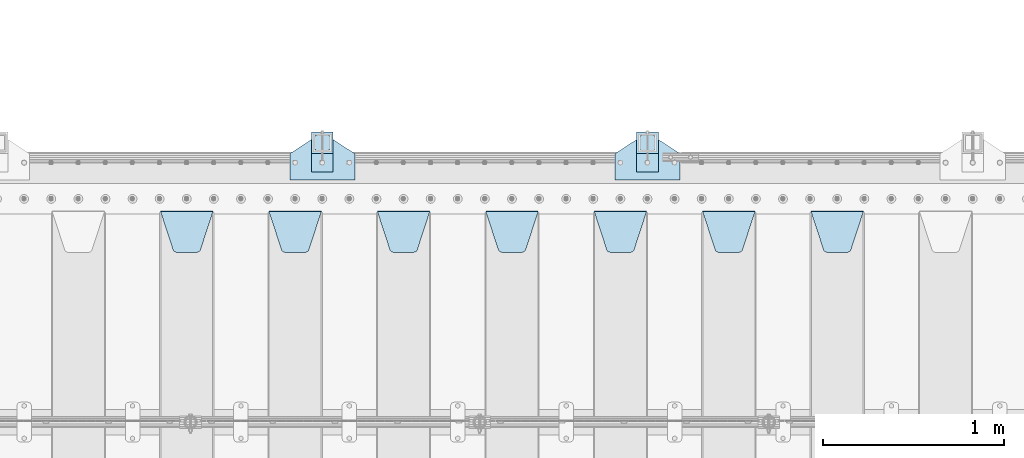
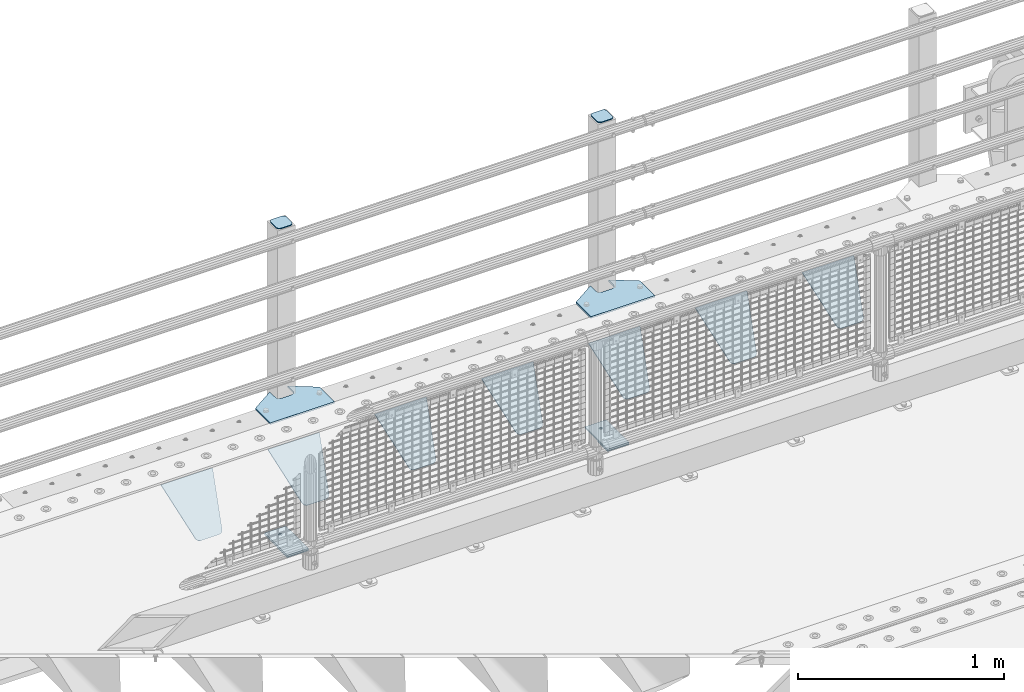
# One storey, part 183 of 208: 15 plates.
"""IFC2X3 building model written with IfcOpenShell, lengths in millimetres."""

from ifc_helpers import new_model, si_unit, frame, origin_with_axes, place, context, subcontext, project, spatial, faceted_brep, material, type_object, element, save


model = new_model("IFC2X3")

# Units and contexts
model_context = context("Model", 3, precision=1e-05, world=origin_with_axes())
body_context = subcontext(model_context, "Body", "Model", "MODEL_VIEW")
ifc_project = project(units=[si_unit("LENGTHUNIT", "METRE", prefix="MILLI"), si_unit("AREAUNIT", "SQUARE_METRE"), si_unit("VOLUMEUNIT", "CUBIC_METRE"), si_unit("MASSUNIT", "GRAM", prefix="KILO"), si_unit("TIMEUNIT", "SECOND"), si_unit("PLANEANGLEUNIT", "RADIAN"), si_unit("SOLIDANGLEUNIT", "STERADIAN"), si_unit("THERMODYNAMICTEMPERATUREUNIT", "DEGREE_CELSIUS"), si_unit("LUMINOUSINTENSITYUNIT", "LUMEN")], contexts=[model_context])

# Site, building, storey
site_placement = place(None, origin_with_axes())
site = spatial("IfcSite", under=ifc_project, at=site_placement, CompositionType="ELEMENT")
building_placement = place(site_placement, origin_with_axes())
building = spatial("IfcBuilding", under=site, at=building_placement, Name="Standard", CompositionType="ELEMENT")
storey_placement = place(building_placement, origin_with_axes())
storey = spatial("IfcBuildingStorey", under=building, at=storey_placement, Name="Undefined", CompositionType="ELEMENT", Elevation=0.0)

# Plates
ifc_material_1 = material(Name="STEEL/S355N")
plate_type_1 = type_object("IfcPlateType", PredefinedType="NOTDEFINED")
plate_1_placement = place(storey_placement, frame((-31995.0, 5831.76776695596, -1.76776695296758), z_axis=(0.0, -0.707106781186548, -0.707106781186547), x_axis=(1.0, 0.0, 0.0)))
element("IfcPlate", 1, at=plate_1_placement, inside=storey, type_object=plate_type_1, material=ifc_material_1, context=body_context, shape_type="Brep", body=[
    faceted_brep([(0.0, -2.5, 0.0), (69.345504679477, -2.5, 300.17173142483), (69.345504679477, 2.5, 300.17173142483), (0.0, 2.5, 0.0), (70.9274061199576, -2.5, 304.897442415399), (70.9274061199576, 2.5, 304.8974424154), (73.3818627772307, -2.5, 309.234538108527), (73.3818627772307, 2.5, 309.234538108527), (76.6187032999551, -2.5, 313.023683126103), (76.6187032999551, 2.5, 313.023683126103), (80.5190132704993, -2.5, 316.125672595371), (80.5190132704993, 2.5, 316.125672595371), (84.9395038596849, -2.5, 318.426546230476), (84.9395038596849, 2.50000000000091, 318.426546230476), (89.7177759439219, -2.5, 319.841774983275), (89.7177759439219, 2.50000000000091, 319.841774983275), (94.678286292652, -2.49999999999909, 320.319366455078), (94.678286292652, 2.5, 320.319366455078), (195.321713707348, -2.49999999999909, 320.319366455078), (195.321713707348, 2.5, 320.319366455078), (200.282224056078, -2.5, 319.841774983275), (200.282224056078, 2.5, 319.841774983274), (205.060496140315, -2.5, 318.426546230475), (205.060496140315, 2.5, 318.426546230475), (209.480986729501, -2.5, 316.125672595371), (209.480986729501, 2.50000000000091, 316.125672595371), (213.381296700045, -2.5, 313.023683126102), (213.381296700045, 2.5, 313.023683126102), (216.618137222769, -2.5, 309.234538108526), (216.618137222769, 2.5, 309.234538108527), (219.072593880042, -2.5, 304.897442415399), (219.072593880042, 2.5, 304.897442415399), (220.654495320523, -2.5, 300.17173142483), (220.654495320523, 2.5, 300.17173142483), (290.0, -2.5, 0.0), (290.0, 2.5, 0.0)], [[[0, 1, 2, 3]], [[1, 4, 5, 2]], [[4, 6, 7, 5]], [[6, 8, 9, 7]], [[8, 10, 11, 9]], [[10, 12, 13, 11]], [[12, 14, 15, 13]], [[14, 16, 17, 15]], [[16, 18, 19, 17]], [[18, 20, 21, 19]], [[20, 22, 23, 21]], [[22, 24, 25, 23]], [[24, 26, 27, 25]], [[26, 28, 29, 27]], [[28, 30, 31, 29]], [[30, 32, 33, 31]], [[32, 34, 35, 33]], [[34, 0, 3, 35]], [[5, 7, 9, 11, 13, 15, 17, 19, 21, 23, 25, 27, 29, 31, 33, 35, 3, 2]], [[34, 32, 30, 28, 26, 24, 22, 20, 18, 16, 14, 12, 10, 8, 6, 4, 1, 0]]]),
])
plate_2_placement = place(storey_placement, frame((-32595.0, 5831.76776695596, -1.76776695296758), z_axis=(0.0, -0.707106781186548, -0.707106781186547), x_axis=(1.0, 0.0, 0.0)))
element("IfcPlate", 2, at=plate_2_placement, inside=storey, type_object=plate_type_1, material=ifc_material_1, context=body_context, shape_type="Brep", body=[
    faceted_brep([(0.0, -2.5, 0.0), (69.345504679477, -2.5, 300.17173142483), (69.345504679477, 2.5, 300.17173142483), (0.0, 2.5, 0.0), (70.9274061199576, -2.5, 304.897442415399), (70.9274061199576, 2.5, 304.8974424154), (73.3818627772307, -2.5, 309.234538108527), (73.3818627772307, 2.5, 309.234538108527), (76.6187032999551, -2.5, 313.023683126103), (76.6187032999551, 2.5, 313.023683126103), (80.5190132704993, -2.5, 316.125672595371), (80.5190132704993, 2.5, 316.125672595371), (84.9395038596849, -2.5, 318.426546230476), (84.9395038596849, 2.50000000000091, 318.426546230476), (89.7177759439219, -2.5, 319.841774983275), (89.7177759439219, 2.50000000000091, 319.841774983275), (94.678286292652, -2.49999999999909, 320.319366455078), (94.678286292652, 2.5, 320.319366455078), (195.321713707348, -2.49999999999909, 320.319366455078), (195.321713707348, 2.5, 320.319366455078), (200.282224056078, -2.5, 319.841774983275), (200.282224056078, 2.5, 319.841774983274), (205.060496140315, -2.5, 318.426546230475), (205.060496140315, 2.5, 318.426546230475), (209.480986729501, -2.5, 316.125672595371), (209.480986729501, 2.50000000000091, 316.125672595371), (213.381296700045, -2.5, 313.023683126102), (213.381296700045, 2.5, 313.023683126102), (216.618137222769, -2.5, 309.234538108526), (216.618137222769, 2.5, 309.234538108527), (219.072593880042, -2.5, 304.897442415399), (219.072593880042, 2.5, 304.897442415399), (220.654495320523, -2.5, 300.17173142483), (220.654495320523, 2.5, 300.17173142483), (290.0, -2.5, 0.0), (290.0, 2.5, 0.0)], [[[0, 1, 2, 3]], [[1, 4, 5, 2]], [[4, 6, 7, 5]], [[6, 8, 9, 7]], [[8, 10, 11, 9]], [[10, 12, 13, 11]], [[12, 14, 15, 13]], [[14, 16, 17, 15]], [[16, 18, 19, 17]], [[18, 20, 21, 19]], [[20, 22, 23, 21]], [[22, 24, 25, 23]], [[24, 26, 27, 25]], [[26, 28, 29, 27]], [[28, 30, 31, 29]], [[30, 32, 33, 31]], [[32, 34, 35, 33]], [[34, 0, 3, 35]], [[5, 7, 9, 11, 13, 15, 17, 19, 21, 23, 25, 27, 29, 31, 33, 35, 3, 2]], [[34, 32, 30, 28, 26, 24, 22, 20, 18, 16, 14, 12, 10, 8, 6, 4, 1, 0]]]),
])
plate_3_placement = place(storey_placement, frame((-33195.0, 5831.76776695596, -1.76776695296758), z_axis=(0.0, -0.707106781186548, -0.707106781186547), x_axis=(1.0, 0.0, 0.0)))
element("IfcPlate", 3, at=plate_3_placement, inside=storey, type_object=plate_type_1, material=ifc_material_1, context=body_context, shape_type="Brep", body=[
    faceted_brep([(0.0, -2.5, 0.0), (69.345504679477, -2.5, 300.17173142483), (69.345504679477, 2.5, 300.17173142483), (0.0, 2.5, 0.0), (70.9274061199576, -2.5, 304.897442415399), (70.9274061199576, 2.5, 304.8974424154), (73.3818627772307, -2.5, 309.234538108527), (73.3818627772307, 2.5, 309.234538108527), (76.6187032999551, -2.5, 313.023683126103), (76.6187032999551, 2.5, 313.023683126103), (80.5190132704993, -2.5, 316.125672595371), (80.5190132704993, 2.5, 316.125672595371), (84.9395038596849, -2.5, 318.426546230476), (84.9395038596849, 2.50000000000091, 318.426546230476), (89.7177759439219, -2.5, 319.841774983275), (89.7177759439219, 2.50000000000091, 319.841774983275), (94.678286292652, -2.49999999999909, 320.319366455078), (94.678286292652, 2.5, 320.319366455078), (195.321713707348, -2.49999999999909, 320.319366455078), (195.321713707348, 2.5, 320.319366455078), (200.282224056078, -2.5, 319.841774983275), (200.282224056078, 2.5, 319.841774983274), (205.060496140315, -2.5, 318.426546230475), (205.060496140315, 2.5, 318.426546230475), (209.480986729501, -2.5, 316.125672595371), (209.480986729501, 2.50000000000091, 316.125672595371), (213.381296700045, -2.5, 313.023683126102), (213.381296700045, 2.5, 313.023683126102), (216.618137222769, -2.5, 309.234538108526), (216.618137222769, 2.5, 309.234538108527), (219.072593880042, -2.5, 304.897442415399), (219.072593880042, 2.5, 304.897442415399), (220.654495320523, -2.5, 300.17173142483), (220.654495320523, 2.5, 300.17173142483), (290.0, -2.5, 0.0), (290.0, 2.5, 0.0)], [[[0, 1, 2, 3]], [[1, 4, 5, 2]], [[4, 6, 7, 5]], [[6, 8, 9, 7]], [[8, 10, 11, 9]], [[10, 12, 13, 11]], [[12, 14, 15, 13]], [[14, 16, 17, 15]], [[16, 18, 19, 17]], [[18, 20, 21, 19]], [[20, 22, 23, 21]], [[22, 24, 25, 23]], [[24, 26, 27, 25]], [[26, 28, 29, 27]], [[28, 30, 31, 29]], [[30, 32, 33, 31]], [[32, 34, 35, 33]], [[34, 0, 3, 35]], [[5, 7, 9, 11, 13, 15, 17, 19, 21, 23, 25, 27, 29, 31, 33, 35, 3, 2]], [[34, 32, 30, 28, 26, 24, 22, 20, 18, 16, 14, 12, 10, 8, 6, 4, 1, 0]]]),
])
plate_4_placement = place(storey_placement, frame((-33795.0, 5831.76776695596, -1.76776695296758), z_axis=(0.0, -0.707106781186548, -0.707106781186547), x_axis=(1.0, 0.0, 0.0)))
element("IfcPlate", 4, at=plate_4_placement, inside=storey, type_object=plate_type_1, material=ifc_material_1, context=body_context, shape_type="Brep", body=[
    faceted_brep([(0.0, -2.5, 0.0), (69.345504679477, -2.5, 300.17173142483), (69.345504679477, 2.5, 300.17173142483), (0.0, 2.5, 0.0), (70.9274061199576, -2.5, 304.897442415399), (70.9274061199576, 2.5, 304.8974424154), (73.3818627772307, -2.5, 309.234538108527), (73.3818627772307, 2.5, 309.234538108527), (76.6187032999551, -2.5, 313.023683126103), (76.6187032999551, 2.5, 313.023683126103), (80.5190132704993, -2.5, 316.125672595371), (80.5190132704993, 2.5, 316.125672595371), (84.9395038596849, -2.5, 318.426546230476), (84.9395038596849, 2.50000000000091, 318.426546230476), (89.7177759439219, -2.5, 319.841774983275), (89.7177759439219, 2.50000000000091, 319.841774983275), (94.678286292652, -2.49999999999909, 320.319366455078), (94.678286292652, 2.5, 320.319366455078), (195.321713707348, -2.49999999999909, 320.319366455078), (195.321713707348, 2.5, 320.319366455078), (200.282224056078, -2.5, 319.841774983275), (200.282224056078, 2.5, 319.841774983274), (205.060496140315, -2.5, 318.426546230475), (205.060496140315, 2.5, 318.426546230475), (209.480986729501, -2.5, 316.125672595371), (209.480986729501, 2.50000000000091, 316.125672595371), (213.381296700045, -2.5, 313.023683126102), (213.381296700045, 2.5, 313.023683126102), (216.618137222769, -2.5, 309.234538108526), (216.618137222769, 2.5, 309.234538108527), (219.072593880042, -2.5, 304.897442415399), (219.072593880042, 2.5, 304.897442415399), (220.654495320523, -2.5, 300.17173142483), (220.654495320523, 2.5, 300.17173142483), (290.0, -2.5, 0.0), (290.0, 2.5, 0.0)], [[[0, 1, 2, 3]], [[1, 4, 5, 2]], [[4, 6, 7, 5]], [[6, 8, 9, 7]], [[8, 10, 11, 9]], [[10, 12, 13, 11]], [[12, 14, 15, 13]], [[14, 16, 17, 15]], [[16, 18, 19, 17]], [[18, 20, 21, 19]], [[20, 22, 23, 21]], [[22, 24, 25, 23]], [[24, 26, 27, 25]], [[26, 28, 29, 27]], [[28, 30, 31, 29]], [[30, 32, 33, 31]], [[32, 34, 35, 33]], [[34, 0, 3, 35]], [[5, 7, 9, 11, 13, 15, 17, 19, 21, 23, 25, 27, 29, 31, 33, 35, 3, 2]], [[34, 32, 30, 28, 26, 24, 22, 20, 18, 16, 14, 12, 10, 8, 6, 4, 1, 0]]]),
])
plate_5_placement = place(storey_placement, frame((-34395.0, 5831.76776695596, -1.76776695296758), z_axis=(0.0, -0.707106781186548, -0.707106781186547), x_axis=(1.0, 0.0, 0.0)))
element("IfcPlate", 5, at=plate_5_placement, inside=storey, type_object=plate_type_1, material=ifc_material_1, context=body_context, shape_type="Brep", body=[
    faceted_brep([(0.0, -2.5, 0.0), (69.345504679477, -2.5, 300.17173142483), (69.345504679477, 2.5, 300.17173142483), (0.0, 2.5, 0.0), (70.9274061199576, -2.5, 304.897442415399), (70.9274061199576, 2.5, 304.8974424154), (73.3818627772307, -2.5, 309.234538108527), (73.3818627772307, 2.5, 309.234538108527), (76.6187032999551, -2.5, 313.023683126103), (76.6187032999551, 2.5, 313.023683126103), (80.5190132704993, -2.5, 316.125672595371), (80.5190132704993, 2.5, 316.125672595371), (84.9395038596849, -2.5, 318.426546230476), (84.9395038596849, 2.50000000000091, 318.426546230476), (89.7177759439219, -2.5, 319.841774983275), (89.7177759439219, 2.50000000000091, 319.841774983275), (94.678286292652, -2.49999999999909, 320.319366455078), (94.678286292652, 2.5, 320.319366455078), (195.321713707348, -2.49999999999909, 320.319366455078), (195.321713707348, 2.5, 320.319366455078), (200.282224056078, -2.5, 319.841774983275), (200.282224056078, 2.5, 319.841774983274), (205.060496140315, -2.5, 318.426546230475), (205.060496140315, 2.5, 318.426546230475), (209.480986729501, -2.5, 316.125672595371), (209.480986729501, 2.50000000000091, 316.125672595371), (213.381296700045, -2.5, 313.023683126102), (213.381296700045, 2.5, 313.023683126102), (216.618137222769, -2.5, 309.234538108526), (216.618137222769, 2.5, 309.234538108527), (219.072593880042, -2.5, 304.897442415399), (219.072593880042, 2.5, 304.897442415399), (220.654495320523, -2.5, 300.17173142483), (220.654495320523, 2.5, 300.17173142483), (290.0, -2.5, 0.0), (290.0, 2.5, 0.0)], [[[0, 1, 2, 3]], [[1, 4, 5, 2]], [[4, 6, 7, 5]], [[6, 8, 9, 7]], [[8, 10, 11, 9]], [[10, 12, 13, 11]], [[12, 14, 15, 13]], [[14, 16, 17, 15]], [[16, 18, 19, 17]], [[18, 20, 21, 19]], [[20, 22, 23, 21]], [[22, 24, 25, 23]], [[24, 26, 27, 25]], [[26, 28, 29, 27]], [[28, 30, 31, 29]], [[30, 32, 33, 31]], [[32, 34, 35, 33]], [[34, 0, 3, 35]], [[5, 7, 9, 11, 13, 15, 17, 19, 21, 23, 25, 27, 29, 31, 33, 35, 3, 2]], [[34, 32, 30, 28, 26, 24, 22, 20, 18, 16, 14, 12, 10, 8, 6, 4, 1, 0]]]),
])
plate_6_placement = place(storey_placement, frame((-34995.0, 5831.76776695596, -1.76776695296758), z_axis=(0.0, -0.707106781186548, -0.707106781186547), x_axis=(1.0, 0.0, 0.0)))
element("IfcPlate", 6, at=plate_6_placement, inside=storey, type_object=plate_type_1, material=ifc_material_1, context=body_context, shape_type="Brep", body=[
    faceted_brep([(0.0, -2.5, 0.0), (69.345504679477, -2.5, 300.17173142483), (69.345504679477, 2.5, 300.17173142483), (0.0, 2.5, 0.0), (70.9274061199576, -2.5, 304.897442415399), (70.9274061199576, 2.5, 304.8974424154), (73.3818627772307, -2.5, 309.234538108527), (73.3818627772307, 2.5, 309.234538108527), (76.6187032999551, -2.5, 313.023683126103), (76.6187032999551, 2.5, 313.023683126103), (80.5190132704993, -2.5, 316.125672595371), (80.5190132704993, 2.5, 316.125672595371), (84.9395038596849, -2.5, 318.426546230476), (84.9395038596849, 2.50000000000091, 318.426546230476), (89.7177759439219, -2.5, 319.841774983275), (89.7177759439219, 2.50000000000091, 319.841774983275), (94.678286292652, -2.49999999999909, 320.319366455078), (94.678286292652, 2.5, 320.319366455078), (195.321713707348, -2.49999999999909, 320.319366455078), (195.321713707348, 2.5, 320.319366455078), (200.282224056078, -2.5, 319.841774983275), (200.282224056078, 2.5, 319.841774983274), (205.060496140315, -2.5, 318.426546230475), (205.060496140315, 2.5, 318.426546230475), (209.480986729501, -2.5, 316.125672595371), (209.480986729501, 2.50000000000091, 316.125672595371), (213.381296700045, -2.5, 313.023683126102), (213.381296700045, 2.5, 313.023683126102), (216.618137222769, -2.5, 309.234538108526), (216.618137222769, 2.5, 309.234538108527), (219.072593880042, -2.5, 304.897442415399), (219.072593880042, 2.5, 304.897442415399), (220.654495320523, -2.5, 300.17173142483), (220.654495320523, 2.5, 300.17173142483), (290.0, -2.5, 0.0), (290.0, 2.5, 0.0)], [[[0, 1, 2, 3]], [[1, 4, 5, 2]], [[4, 6, 7, 5]], [[6, 8, 9, 7]], [[8, 10, 11, 9]], [[10, 12, 13, 11]], [[12, 14, 15, 13]], [[14, 16, 17, 15]], [[16, 18, 19, 17]], [[18, 20, 21, 19]], [[20, 22, 23, 21]], [[22, 24, 25, 23]], [[24, 26, 27, 25]], [[26, 28, 29, 27]], [[28, 30, 31, 29]], [[30, 32, 33, 31]], [[32, 34, 35, 33]], [[34, 0, 3, 35]], [[5, 7, 9, 11, 13, 15, 17, 19, 21, 23, 25, 27, 29, 31, 33, 35, 3, 2]], [[34, 32, 30, 28, 26, 24, 22, 20, 18, 16, 14, 12, 10, 8, 6, 4, 1, 0]]]),
])
plate_7_placement = place(storey_placement, frame((-35595.0, 5831.76776695596, -1.76776695296758), z_axis=(0.0, -0.707106781186548, -0.707106781186547), x_axis=(1.0, 0.0, 0.0)))
element("IfcPlate", 7, at=plate_7_placement, inside=storey, type_object=plate_type_1, material=ifc_material_1, context=body_context, shape_type="Brep", body=[
    faceted_brep([(0.0, -2.5, 0.0), (69.345504679477, -2.5, 300.17173142483), (69.345504679477, 2.5, 300.17173142483), (0.0, 2.5, 0.0), (70.9274061199576, -2.5, 304.897442415399), (70.9274061199576, 2.5, 304.8974424154), (73.3818627772307, -2.5, 309.234538108527), (73.3818627772307, 2.5, 309.234538108527), (76.6187032999551, -2.5, 313.023683126103), (76.6187032999551, 2.5, 313.023683126103), (80.5190132704993, -2.5, 316.125672595371), (80.5190132704993, 2.5, 316.125672595371), (84.9395038596849, -2.5, 318.426546230476), (84.9395038596849, 2.50000000000091, 318.426546230476), (89.7177759439219, -2.5, 319.841774983275), (89.7177759439219, 2.50000000000091, 319.841774983275), (94.678286292652, -2.49999999999909, 320.319366455078), (94.678286292652, 2.5, 320.319366455078), (195.321713707348, -2.49999999999909, 320.319366455078), (195.321713707348, 2.5, 320.319366455078), (200.282224056078, -2.5, 319.841774983275), (200.282224056078, 2.5, 319.841774983274), (205.060496140315, -2.5, 318.426546230475), (205.060496140315, 2.5, 318.426546230475), (209.480986729501, -2.5, 316.125672595371), (209.480986729501, 2.50000000000091, 316.125672595371), (213.381296700045, -2.5, 313.023683126102), (213.381296700045, 2.5, 313.023683126102), (216.618137222769, -2.5, 309.234538108526), (216.618137222769, 2.5, 309.234538108527), (219.072593880042, -2.5, 304.897442415399), (219.072593880042, 2.5, 304.897442415399), (220.654495320523, -2.5, 300.17173142483), (220.654495320523, 2.5, 300.17173142483), (290.0, -2.5, 0.0), (290.0, 2.5, 0.0)], [[[0, 1, 2, 3]], [[1, 4, 5, 2]], [[4, 6, 7, 5]], [[6, 8, 9, 7]], [[8, 10, 11, 9]], [[10, 12, 13, 11]], [[12, 14, 15, 13]], [[14, 16, 17, 15]], [[16, 18, 19, 17]], [[18, 20, 21, 19]], [[20, 22, 23, 21]], [[22, 24, 25, 23]], [[24, 26, 27, 25]], [[26, 28, 29, 27]], [[28, 30, 31, 29]], [[30, 32, 33, 31]], [[32, 34, 35, 33]], [[34, 0, 3, 35]], [[5, 7, 9, 11, 13, 15, 17, 19, 21, 23, 25, 27, 29, 31, 33, 35, 3, 2]], [[34, 32, 30, 28, 26, 24, 22, 20, 18, 16, 14, 12, 10, 8, 6, 4, 1, 0]]]),
])
ifc_material_2 = material(Name="STEEL/S355J2")
plate_type_2 = type_object("IfcPlateType", PredefinedType="NOTDEFINED")
plate_8_placement = place(storey_placement, frame((-33080.0, 6005.0, 5.00000000004911), z_axis=(0.0, 1.0, 0.0), x_axis=(1.0, 0.0, 0.0)))
element("IfcPlate", 8, at=plate_8_placement, inside=storey, type_object=plate_type_2, material=ifc_material_2, context=body_context, shape_type="Brep", body=[
    faceted_brep([(0.0, -5.0, 0.0), (2.31396552408114e-06, -5.0, 145.0), (2.31396552408114e-06, 5.0, 145.0), (0.0, 5.0, 0.0), (130.0, -5.0, 230.0), (130.0, 5.0, 230.0), (130.0, -5.0, 180.0), (130.0, 5.0, 180.0), (130.48036798992, -5.0, 175.122741949597), (130.48036798992, 5.0, 175.122741949597), (131.903011687216, -5.0, 170.432914190873), (131.903011687216, 5.0, 170.432914190873), (134.213259692435, -5.0, 166.11074417451), (134.213259692435, 5.0, 166.11074417451), (137.322330470335, -5.0, 162.322330470336), (137.322330470335, 5.0, 162.322330470336), (141.110744174512, -5.0, 159.213259692437), (141.110744174512, 5.0, 159.213259692437), (145.432914190871, -5.0, 156.903011687218), (145.432914190871, 5.0, 156.903011687218), (150.122741949595, -5.0, 155.48036798992), (150.122741949595, 5.0, 155.48036798992), (155.0, -5.0, 155.0), (155.0, 5.0, 155.0), (205.0, -5.0, 155.0), (205.0, 5.0, 155.0), (209.877258050405, -5.0, 155.48036798992), (209.877258050405, 5.0, 155.48036798992), (214.567085809129, -5.0, 156.903011687218), (214.567085809129, 5.0, 156.903011687218), (218.889255825488, -5.0, 159.213259692437), (218.889255825488, 5.0, 159.213259692437), (222.677669529665, -5.0, 162.322330470336), (222.677669529665, 5.0, 162.322330470336), (225.786740307565, -5.0, 166.11074417451), (225.786740307565, 5.0, 166.11074417451), (228.096988312784, -5.0, 170.432914190873), (228.096988312784, 5.0, 170.432914190873), (229.51963201008, -5.0, 175.122741949597), (229.51963201008, 5.0, 175.122741949597), (230.0, -5.0, 180.0), (230.0, 5.0, 180.0), (230.0, -5.0, 230.0), (230.0, 5.0, 230.0), (360.0, -5.0, 145.0), (360.0, 5.0, 145.0), (360.0, -5.0, -7.27595761418343e-12), (360.0, 5.0, -7.27595761418343e-12)], [[[0, 1, 2, 3]], [[1, 4, 5, 2]], [[4, 6, 7, 5]], [[6, 8, 9, 7]], [[8, 10, 11, 9]], [[10, 12, 13, 11]], [[12, 14, 15, 13]], [[14, 16, 17, 15]], [[16, 18, 19, 17]], [[18, 20, 21, 19]], [[20, 22, 23, 21]], [[22, 24, 25, 23]], [[24, 26, 27, 25]], [[26, 28, 29, 27]], [[28, 30, 31, 29]], [[30, 32, 33, 31]], [[32, 34, 35, 33]], [[34, 36, 37, 35]], [[36, 38, 39, 37]], [[38, 40, 41, 39]], [[40, 42, 43, 41]], [[42, 44, 45, 43]], [[44, 46, 47, 45]], [[46, 0, 3, 47]], [[5, 7, 9, 11, 13, 15, 17, 19, 21, 23, 25, 27, 29, 31, 33, 35, 37, 39, 41, 43, 45, 47, 3, 2]], [[46, 44, 42, 40, 38, 36, 34, 32, 30, 28, 26, 24, 22, 20, 18, 16, 14, 12, 10, 8, 6, 4, 1, 0]]]),
])
plate_9_placement = place(storey_placement, frame((-34880.0, 6005.0, 5.00000000004911), z_axis=(0.0, 1.0, 0.0), x_axis=(1.0, 0.0, 0.0)))
element("IfcPlate", 9, at=plate_9_placement, inside=storey, type_object=plate_type_2, material=ifc_material_2, context=body_context, shape_type="Brep", body=[
    faceted_brep([(0.0, -5.0, 0.0), (2.31396552408114e-06, -5.0, 145.0), (2.31396552408114e-06, 5.0, 145.0), (0.0, 5.0, 0.0), (130.0, -5.0, 230.0), (130.0, 5.0, 230.0), (130.0, -5.0, 180.0), (130.0, 5.0, 180.0), (130.48036798992, -5.0, 175.122741949597), (130.48036798992, 5.0, 175.122741949597), (131.903011687216, -5.0, 170.432914190873), (131.903011687216, 5.0, 170.432914190873), (134.213259692435, -5.0, 166.11074417451), (134.213259692435, 5.0, 166.11074417451), (137.322330470335, -5.0, 162.322330470336), (137.322330470335, 5.0, 162.322330470336), (141.110744174512, -5.0, 159.213259692437), (141.110744174512, 5.0, 159.213259692437), (145.432914190871, -5.0, 156.903011687218), (145.432914190871, 5.0, 156.903011687218), (150.122741949595, -5.0, 155.48036798992), (150.122741949595, 5.0, 155.48036798992), (155.0, -5.0, 155.0), (155.0, 5.0, 155.0), (205.0, -5.0, 155.0), (205.0, 5.0, 155.0), (209.877258050405, -5.0, 155.48036798992), (209.877258050405, 5.0, 155.48036798992), (214.567085809129, -5.0, 156.903011687218), (214.567085809129, 5.0, 156.903011687218), (218.889255825488, -5.0, 159.213259692437), (218.889255825488, 5.0, 159.213259692437), (222.677669529665, -5.0, 162.322330470336), (222.677669529665, 5.0, 162.322330470336), (225.786740307565, -5.0, 166.11074417451), (225.786740307565, 5.0, 166.11074417451), (228.096988312784, -5.0, 170.432914190873), (228.096988312784, 5.0, 170.432914190873), (229.51963201008, -5.0, 175.122741949597), (229.51963201008, 5.0, 175.122741949597), (230.0, -5.0, 180.0), (230.0, 5.0, 180.0), (230.0, -5.0, 230.0), (230.0, 5.0, 230.0), (360.0, -5.0, 145.0), (360.0, 5.0, 145.0), (360.0, -5.0, -7.27595761418343e-12), (360.0, 5.0, -7.27595761418343e-12)], [[[0, 1, 2, 3]], [[1, 4, 5, 2]], [[4, 6, 7, 5]], [[6, 8, 9, 7]], [[8, 10, 11, 9]], [[10, 12, 13, 11]], [[12, 14, 15, 13]], [[14, 16, 17, 15]], [[16, 18, 19, 17]], [[18, 20, 21, 19]], [[20, 22, 23, 21]], [[22, 24, 25, 23]], [[24, 26, 27, 25]], [[26, 28, 29, 27]], [[28, 30, 31, 29]], [[30, 32, 33, 31]], [[32, 34, 35, 33]], [[34, 36, 37, 35]], [[36, 38, 39, 37]], [[38, 40, 41, 39]], [[40, 42, 43, 41]], [[42, 44, 45, 43]], [[44, 46, 47, 45]], [[46, 0, 3, 47]], [[5, 7, 9, 11, 13, 15, 17, 19, 21, 23, 25, 27, 29, 31, 33, 35, 37, 39, 41, 43, 45, 47, 3, 2]], [[46, 44, 42, 40, 38, 36, 34, 32, 30, 28, 26, 24, 22, 20, 18, 16, 14, 12, 10, 8, 6, 4, 1, 0]]]),
])
plate_type_3 = type_object("IfcPlateType", PredefinedType="NOTDEFINED")
for number, where, z_axis, x_axis in (
    (10, (-32959.9999999999, 6050.00000000021, -850.000000000002), (0.0, 1.0, 0.0), (1.0, 0.0, 0.0)),
    (11, (-34759.9999999999, 6050.00000000021, -850.000000000002), (0.0, 1.0, 0.0), (1.0, 0.0, 0.0)),
):
    element("IfcPlate", number, at=place(storey_placement, frame(where, z_axis=z_axis, x_axis=x_axis)), inside=storey, type_object=plate_type_3, material=ifc_material_2, context=body_context, shape_type="Brep", body=[
        faceted_brep([(66.3639610305399, -5.0, 163.636038969112), (66.3639610305399, 5.0, 163.636038969112), (59.9999999998618, 5.0, 160.999999999791), (59.9999999998618, -5.0, 160.999999999791), (53.6360389691836, 5.0, 163.636038969112), (53.6360389691836, -5.0, 163.636038969112), (50.9999999998618, 5.0, 169.999999999791), (50.9999999998618, -5.0, 169.999999999791), (53.6360389691836, 5.0, 176.36396103047), (53.6360389691836, -5.0, 176.36396103047), (59.9999999998618, 5.0, 178.999999999791), (59.9999999998618, -5.0, 178.999999999791), (66.3639610305399, 5.0, 176.36396103047), (66.3639610305399, -5.0, 176.36396103047), (68.9999999998618, 5.0, 169.999999999791), (68.9999999998618, -5.0, 169.999999999791), (120.0, -5.0, 0.0), (120.0, -5.0, 220.0), (0.0, -5.0, 220.0), (0.0, -5.0, 0.0), (0.0, 5.0, 0.0), (120.0, 5.0, 0.0), (120.0, 5.0, 220.0), (0.0, 5.0, 220.0)], [[[0, 1, 2, 3]], [[3, 2, 4, 5]], [[5, 4, 6, 7]], [[7, 6, 8, 9]], [[9, 8, 10, 11]], [[11, 10, 12, 13]], [[13, 12, 14, 15]], [[15, 14, 1, 0]], [[16, 17, 18, 19], [3, 5, 7, 9, 11, 13, 15, 0]], [[16, 19, 20, 21]], [[17, 16, 21, 22]], [[18, 17, 22, 23]], [[19, 18, 23, 20]], [[22, 21, 20, 23], [10, 8, 6, 4, 2, 1, 14, 12]]]),
    ])
plate_type_4 = type_object("IfcPlateType", PredefinedType="NOTDEFINED")
plate_10_placement = place(storey_placement, frame((-32855.9999999999, 6166.00000000021, 1012.50000000001), z_axis=(0.0, 1.0, 0.0), x_axis=(-1.0, 0.0, 0.0)))
element("IfcPlate", 12, at=plate_10_placement, inside=storey, type_object=plate_type_4, material=ifc_material_2, context=body_context, shape_type="Brep", body=[
    faceted_brep([(0.0, -2.5, 19.0), (0.0, -2.5, 69.0), (0.0, 2.5, 69.0), (0.0, 2.5, 19.0), (0.476369668544066, -2.5, 73.2278977451697), (0.476369668544066, 2.5, 73.2278977451697), (1.88159150985302, -2.5, 77.2437910432336), (1.88159150985302, 2.5, 77.2437910432336), (4.14520183310742, -2.5, 80.8463062353158), (4.14520183310742, 2.5, 80.8463062353158), (7.15369376468516, -2.5, 83.8547981668926), (7.15369376468516, 2.5, 83.8547981668926), (10.7562089567655, -2.5, 86.1184084901461), (10.7562089567655, 2.5, 86.1184084901461), (14.7721022548285, -2.5, 87.523630331455), (14.7721022548285, 2.5, 87.523630331455), (19.0, -2.5, 88.0), (19.0, 2.5, 88.0), (69.0, -2.5, 88.0), (69.0, 2.5, 88.0), (73.2278977451715, -2.5, 87.523630331455), (73.2278977451715, 2.5, 87.523630331455), (77.2437910432345, -2.5, 86.1184084901461), (77.2437910432345, 2.5, 86.1184084901461), (80.8463062353148, -2.5, 83.8547981668926), (80.8463062353148, 2.5, 83.8547981668926), (83.8547981668926, -2.5, 80.8463062353158), (83.8547981668926, 2.5, 80.8463062353158), (86.118408490147, -2.5, 77.2437910432336), (86.118408490147, 2.5, 77.2437910432336), (87.5236303314559, -2.5, 73.2278977451697), (87.5236303314559, 2.5, 73.2278977451697), (88.0, -2.5, 69.0), (88.0, 2.5, 69.0), (88.0, -2.5, 19.0), (88.0, 2.5, 19.0), (87.5236303314559, -2.5, 14.7721022548303), (87.5236303314559, 2.5, 14.7721022548303), (86.118408490147, -2.5, 10.7562089567664), (86.118408490147, 2.5, 10.7562089567664), (83.8547981668926, -2.5, 7.15369376468425), (83.8547981668926, 2.5, 7.15369376468425), (80.8463062353148, -2.5, 4.14520183310742), (80.8463062353148, 2.5, 4.14520183310742), (77.2437910432345, -2.5, 1.88159150985393), (77.2437910432345, 2.5, 1.88159150985393), (73.2278977451715, -2.5, 0.476369668544976), (73.2278977451715, 2.5, 0.476369668544976), (69.0, -2.5, 0.0), (69.0, 2.5, 0.0), (19.0, -2.5, 0.0), (19.0, 2.5, 0.0), (14.7721022548285, -2.5, 0.476369668544976), (14.7721022548285, 2.5, 0.476369668544976), (10.7562089567655, -2.5, 1.88159150985393), (10.7562089567655, 2.5, 1.88159150985393), (7.15369376468516, -2.5, 4.14520183310742), (7.15369376468516, 2.5, 4.14520183310742), (4.14520183310742, -2.5, 7.15369376468425), (4.14520183310742, 2.5, 7.15369376468425), (1.88159150985302, -2.5, 10.7562089567664), (1.88159150985302, 2.5, 10.7562089567664), (0.476369668544066, -2.5, 14.7721022548303), (0.476369668544066, 2.5, 14.7721022548303)], [[[0, 1, 2, 3]], [[1, 4, 5, 2]], [[4, 6, 7, 5]], [[6, 8, 9, 7]], [[8, 10, 11, 9]], [[10, 12, 13, 11]], [[12, 14, 15, 13]], [[14, 16, 17, 15]], [[16, 18, 19, 17]], [[18, 20, 21, 19]], [[20, 22, 23, 21]], [[22, 24, 25, 23]], [[24, 26, 27, 25]], [[26, 28, 29, 27]], [[28, 30, 31, 29]], [[30, 32, 33, 31]], [[32, 34, 35, 33]], [[34, 36, 37, 35]], [[36, 38, 39, 37]], [[38, 40, 41, 39]], [[40, 42, 43, 41]], [[42, 44, 45, 43]], [[44, 46, 47, 45]], [[46, 48, 49, 47]], [[48, 50, 51, 49]], [[50, 52, 53, 51]], [[52, 54, 55, 53]], [[54, 56, 57, 55]], [[56, 58, 59, 57]], [[58, 60, 61, 59]], [[60, 62, 63, 61]], [[62, 0, 3, 63]], [[5, 7, 9, 11, 13, 15, 17, 19, 21, 23, 25, 27, 29, 31, 33, 35, 37, 39, 41, 43, 45, 47, 49, 51, 53, 55, 57, 59, 61, 63, 3, 2]], [[62, 60, 58, 56, 54, 52, 50, 48, 46, 44, 42, 40, 38, 36, 34, 32, 30, 28, 26, 24, 22, 20, 18, 16, 14, 12, 10, 8, 6, 4, 1, 0]]]),
])
plate_11_placement = place(storey_placement, frame((-34655.9999999999, 6166.00000000021, 1012.50000000001), z_axis=(0.0, 1.0, 0.0), x_axis=(-1.0, 0.0, 0.0)))
element("IfcPlate", 13, at=plate_11_placement, inside=storey, type_object=plate_type_4, material=ifc_material_2, context=body_context, shape_type="Brep", body=[
    faceted_brep([(0.0, -2.5, 19.0), (0.0, -2.5, 69.0), (0.0, 2.5, 69.0), (0.0, 2.5, 19.0), (0.476369668544066, -2.5, 73.2278977451697), (0.476369668544066, 2.5, 73.2278977451697), (1.88159150985302, -2.5, 77.2437910432336), (1.88159150985302, 2.5, 77.2437910432336), (4.14520183310742, -2.5, 80.8463062353158), (4.14520183310742, 2.5, 80.8463062353158), (7.15369376468516, -2.5, 83.8547981668926), (7.15369376468516, 2.5, 83.8547981668926), (10.7562089567655, -2.5, 86.1184084901461), (10.7562089567655, 2.5, 86.1184084901461), (14.7721022548285, -2.5, 87.523630331455), (14.7721022548285, 2.5, 87.523630331455), (19.0, -2.5, 88.0), (19.0, 2.5, 88.0), (69.0, -2.5, 88.0), (69.0, 2.5, 88.0), (73.2278977451715, -2.5, 87.523630331455), (73.2278977451715, 2.5, 87.523630331455), (77.2437910432345, -2.5, 86.1184084901461), (77.2437910432345, 2.5, 86.1184084901461), (80.8463062353148, -2.5, 83.8547981668926), (80.8463062353148, 2.5, 83.8547981668926), (83.8547981668926, -2.5, 80.8463062353158), (83.8547981668926, 2.5, 80.8463062353158), (86.118408490147, -2.5, 77.2437910432336), (86.118408490147, 2.5, 77.2437910432336), (87.5236303314559, -2.5, 73.2278977451697), (87.5236303314559, 2.5, 73.2278977451697), (88.0, -2.5, 69.0), (88.0, 2.5, 69.0), (88.0, -2.5, 19.0), (88.0, 2.5, 19.0), (87.5236303314559, -2.5, 14.7721022548303), (87.5236303314559, 2.5, 14.7721022548303), (86.118408490147, -2.5, 10.7562089567664), (86.118408490147, 2.5, 10.7562089567664), (83.8547981668926, -2.5, 7.15369376468425), (83.8547981668926, 2.5, 7.15369376468425), (80.8463062353148, -2.5, 4.14520183310742), (80.8463062353148, 2.5, 4.14520183310742), (77.2437910432345, -2.5, 1.88159150985393), (77.2437910432345, 2.5, 1.88159150985393), (73.2278977451715, -2.5, 0.476369668544976), (73.2278977451715, 2.5, 0.476369668544976), (69.0, -2.5, 0.0), (69.0, 2.5, 0.0), (19.0, -2.5, 0.0), (19.0, 2.5, 0.0), (14.7721022548285, -2.5, 0.476369668544976), (14.7721022548285, 2.5, 0.476369668544976), (10.7562089567655, -2.5, 1.88159150985393), (10.7562089567655, 2.5, 1.88159150985393), (7.15369376468516, -2.5, 4.14520183310742), (7.15369376468516, 2.5, 4.14520183310742), (4.14520183310742, -2.5, 7.15369376468425), (4.14520183310742, 2.5, 7.15369376468425), (1.88159150985302, -2.5, 10.7562089567664), (1.88159150985302, 2.5, 10.7562089567664), (0.476369668544066, -2.5, 14.7721022548303), (0.476369668544066, 2.5, 14.7721022548303)], [[[0, 1, 2, 3]], [[1, 4, 5, 2]], [[4, 6, 7, 5]], [[6, 8, 9, 7]], [[8, 10, 11, 9]], [[10, 12, 13, 11]], [[12, 14, 15, 13]], [[14, 16, 17, 15]], [[16, 18, 19, 17]], [[18, 20, 21, 19]], [[20, 22, 23, 21]], [[22, 24, 25, 23]], [[24, 26, 27, 25]], [[26, 28, 29, 27]], [[28, 30, 31, 29]], [[30, 32, 33, 31]], [[32, 34, 35, 33]], [[34, 36, 37, 35]], [[36, 38, 39, 37]], [[38, 40, 41, 39]], [[40, 42, 43, 41]], [[42, 44, 45, 43]], [[44, 46, 47, 45]], [[46, 48, 49, 47]], [[48, 50, 51, 49]], [[50, 52, 53, 51]], [[52, 54, 55, 53]], [[54, 56, 57, 55]], [[56, 58, 59, 57]], [[58, 60, 61, 59]], [[60, 62, 63, 61]], [[62, 0, 3, 63]], [[5, 7, 9, 11, 13, 15, 17, 19, 21, 23, 25, 27, 29, 31, 33, 35, 37, 39, 41, 43, 45, 47, 49, 51, 53, 55, 57, 59, 61, 63, 3, 2]], [[62, 60, 58, 56, 54, 52, 50, 48, 46, 44, 42, 40, 38, 36, 34, 32, 30, 28, 26, 24, 22, 20, 18, 16, 14, 12, 10, 8, 6, 4, 1, 0]]]),
])
plate_type_5 = type_object("IfcPlateType", PredefinedType="NOTDEFINED")
for number, where, z_axis, x_axis in (
    (14, (-32959.9999999999, 6050.00000000021, -857.500000000002), (0.0, 1.0, 0.0), (1.0, 0.0, 0.0)),
    (15, (-34759.9999999999, 6050.00000000021, -857.500000000002), (0.0, 1.0, 0.0), (1.0, 0.0, 0.0)),
):
    element("IfcPlate", number, at=place(storey_placement, frame(where, z_axis=z_axis, x_axis=x_axis)), inside=storey, type_object=plate_type_5, material=ifc_material_2, context=body_context, shape_type="Brep", body=[
        faceted_brep([(0.0, -2.5, 0.0), (0.0, -2.5, 100.0), (0.0, 2.5, 100.0), (0.0, 2.5, 0.0), (120.0, -2.5, 100.0), (120.0, 2.5, 100.0), (120.0, -2.5, 0.0), (120.0, 2.5, 0.0)], [[[0, 1, 2, 3]], [[1, 4, 5, 2]], [[4, 6, 7, 5]], [[6, 0, 3, 7]], [[5, 7, 3, 2]], [[6, 4, 1, 0]]]),
    ])

save(model, "model.ifc")
